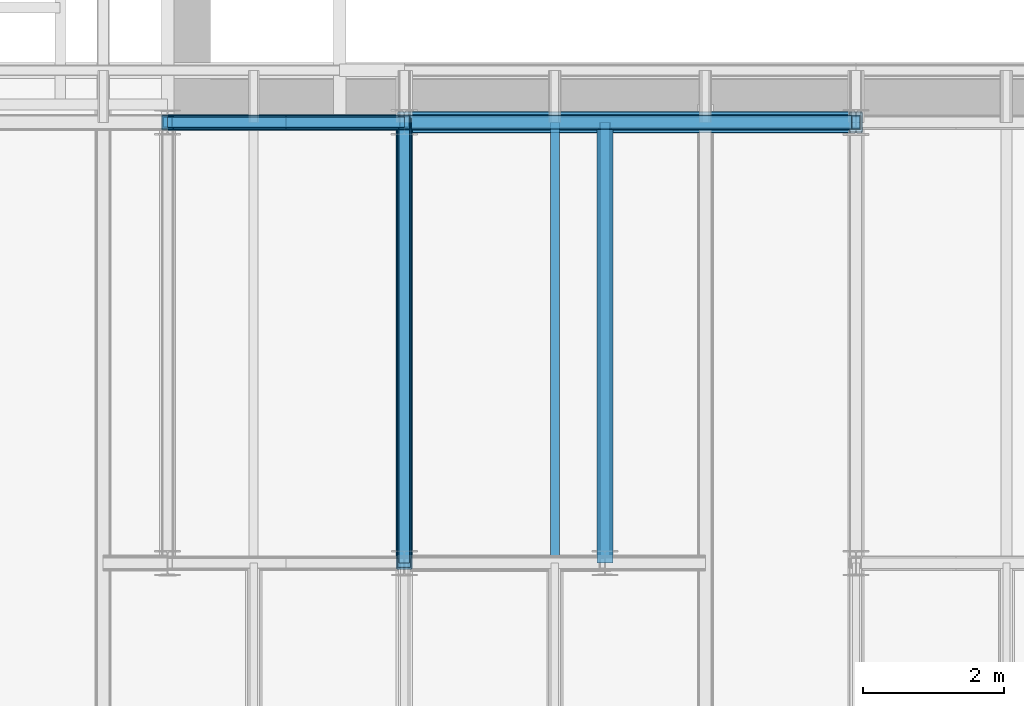
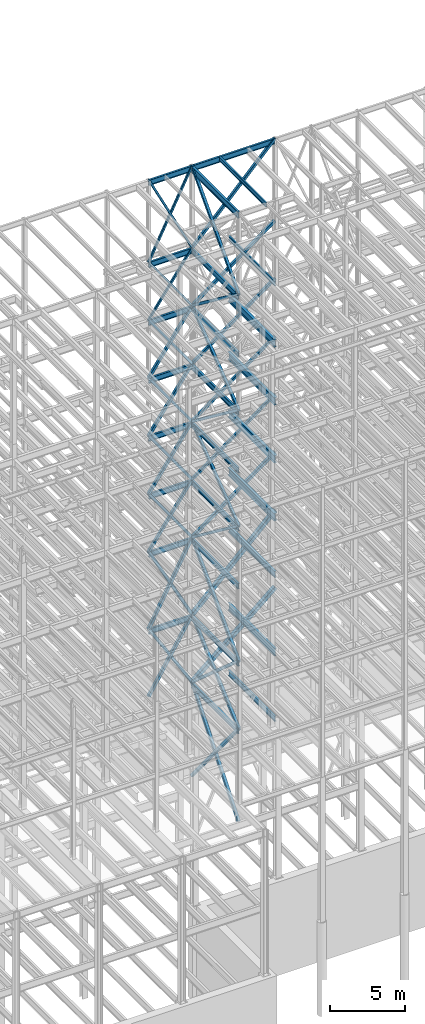
# One storey, part 135 of 150: 62 beams.
"""IFC2X3 building model written with IfcOpenShell, lengths in millimetres."""

from ifc_helpers import new_model, si_unit, frame, origin_with_axes, origin_2d_with_axis, place, context, subcontext, project, spatial, hollow_rectangle, i_section, extrude, material, type_object, element, save


model = new_model("IFC2X3")

# Units and contexts
model_context = context("Model", 3, precision=1e-05, world=origin_with_axes())
body_context = subcontext(model_context, "Body", "Model", "MODEL_VIEW")
ifc_project = project(units=[si_unit("LENGTHUNIT", "METRE", prefix="MILLI"), si_unit("AREAUNIT", "SQUARE_METRE"), si_unit("VOLUMEUNIT", "CUBIC_METRE"), si_unit("MASSUNIT", "GRAM", prefix="KILO"), si_unit("TIMEUNIT", "SECOND"), si_unit("PLANEANGLEUNIT", "RADIAN"), si_unit("SOLIDANGLEUNIT", "STERADIAN"), si_unit("THERMODYNAMICTEMPERATUREUNIT", "DEGREE_CELSIUS"), si_unit("LUMINOUSINTENSITYUNIT", "LUMEN")], contexts=[model_context])

# Site, building, storey
site_placement = place(None, origin_with_axes())
site = spatial("IfcSite", under=ifc_project, at=site_placement, CompositionType="ELEMENT")
building_placement = place(site_placement, origin_with_axes())
building = spatial("IfcBuilding", under=site, at=building_placement, Name="Undefined", CompositionType="ELEMENT")
storey_placement = place(building_placement, origin_with_axes())
storey = spatial("IfcBuildingStorey", under=building, at=storey_placement, Name="Undefined", CompositionType="ELEMENT", Elevation=0.0)

# Beams
ifc_material_1 = material()
beam_type_1 = type_object("IfcBeamType", Name="HSS8X8X3/8", PredefinedType="NOTDEFINED")
for number, where, z_axis, x_axis, name in (
    (1, (56591.2, 31877.0, 45034.2), (0.0, 0.603108242282795, 0.797659355922412), (0.0, -0.797659355922412, 0.603108242282795), "BEAM"),
    (2, (56591.2, 25628.6, 40309.8), (0.0, -0.603108242282795, 0.797659355922412), (0.0, 0.797659355922412, 0.603108242282795), "BEAM"),
    (3, (56591.2, 31877.0, 35585.4), (0.0, 0.603108242282795, 0.797659355922412), (0.0, -0.797659355922412, 0.603108242282795), "BEAM"),
):
    element("IfcBeam", number, at=place(storey_placement, frame(where, z_axis=z_axis, x_axis=x_axis)), inside=storey, type_object=beam_type_1, material=ifc_material_1, Name=name, ObjectType="HSS8X8X3/8", context=body_context, shape_type="SweptSolid", body=[
        extrude(hollow_rectangle(XDim=203.2, YDim=203.2, WallThickness=9.525, InnerFilletRadius=9.5249, OuterFilletRadius=19.0499, at=origin_2d_with_axis()), frame((7833.41929938644, 0.0, 0.0), z_axis=(-1.0, 0.0, 0.0), x_axis=(0.0, -1.0, 0.0)), (0.0, 0.0, 1.0), 7833.41929938644),
    ])
beam_1_placement = place(storey_placement, frame((56591.2, 31877.0, 49758.6), z_axis=(-0.593852272176556, 0.0, 0.804574097787607), x_axis=(0.804574097787604, 0.0, 0.59385227217656)))
element("IfcBeam", 4, at=beam_1_placement, inside=storey, type_object=beam_type_1, material=ifc_material_1, Name="BEAM", ObjectType="HSS8X8X3/8", context=body_context, shape_type="SweptSolid", body=[
    extrude(hollow_rectangle(XDim=203.2, YDim=203.2, WallThickness=9.525, InnerFilletRadius=9.5249, OuterFilletRadius=19.0499, at=origin_2d_with_axis()), frame((7955.51355978985, 0.0, -1.81898940354586e-12), z_axis=(-1.0, 0.0, 0.0), x_axis=(0.0, -1.0, 0.0)), (0.0, 0.0, 1.0), 7955.51355978984),
])
for number, where, z_axis, x_axis, name in (
    (5, (56591.2, 31877.0, 40309.8), (0.815507132555285, 0.0, 0.578747023103753), (-0.578747023103752, 0.0, 0.815507132555286), "BEAM"),
    (6, (53238.4, 31877.0, 40309.8), (-0.815507179752522, 0.0, 0.578746956598553), (0.578746956598556, 0.0, 0.81550717975252), "BEAM"),
    (7, (56591.2, 31877.0, 35585.4), (0.815507132555285, 0.0, 0.578747023103753), (-0.578747023103752, 0.0, 0.815507132555286), "BEAM"),
    (8, (53238.4, 31877.0, 35585.4), (-0.815507179752522, 0.0, 0.578746956598553), (0.578746956598556, 0.0, 0.81550717975252), "BEAM"),
):
    element("IfcBeam", number, at=place(storey_placement, frame(where, z_axis=z_axis, x_axis=x_axis)), inside=storey, type_object=beam_type_1, material=ifc_material_1, Name=name, ObjectType="HSS8X8X3/8", context=body_context, shape_type="SweptSolid", body=[
        extrude(hollow_rectangle(XDim=203.2, YDim=203.2, WallThickness=9.525, InnerFilletRadius=9.5249, OuterFilletRadius=19.0499, at=origin_2d_with_axis()), frame((5793.20491610646, 0.0, -3.21587474211652e-13), z_axis=(-1.0, 0.0, 0.0), x_axis=(0.0, -1.0, 0.0)), (0.0, 0.0, 1.0), 5793.20491610646),
    ])
ifc_material_2 = material(Name="STEEL/A992")
beam_type_2 = type_object("IfcBeamType", Name="W18X35", PredefinedType="NOTDEFINED")
beam_2_placement = place(storey_placement, frame((56591.2, 31877.0, 65687.575), z_axis=(0.0, 0.0, 1.0), x_axis=(1.0, 0.0, 0.0)))
element("IfcBeam", 9, at=beam_2_placement, inside=storey, type_object=beam_type_2, material=ifc_material_2, Name="BEAM", ObjectType="W18X35", context=body_context, shape_type="SweptSolid", body=[
    extrude(i_section(OverallWidth=152.4, OverallDepth=450.85, WebThickness=7.9375, FlangeThickness=10.795, FilletRadius=17.78, at=origin_2d_with_axis()), frame((6400.80000000001, 0.0, 0.0), z_axis=(-1.0, 0.0, 0.0), x_axis=(0.0, -1.0, 0.0)), (0.0, 0.0, 1.0), 6400.80000000001),
])
beam_3_placement = place(storey_placement, frame((53238.4, 31877.0, 65687.575), z_axis=(0.0, 0.0, 1.0), x_axis=(1.0, 0.0, 0.0)))
element("IfcBeam", 10, at=beam_3_placement, inside=storey, type_object=beam_type_2, material=ifc_material_2, Name="BEAM", ObjectType="W18X35", context=body_context, shape_type="SweptSolid", body=[
    extrude(i_section(OverallWidth=152.4, OverallDepth=450.85, WebThickness=7.9375, FlangeThickness=10.795, FilletRadius=17.78, at=origin_2d_with_axis()), frame((3352.8, 0.0, 0.0), z_axis=(-1.0, 0.0, 0.0), x_axis=(0.0, -1.0, 0.0)), (0.0, 0.0, 1.0), 3352.8),
])
beam_4_placement = place(storey_placement, frame((56591.2, 25628.6, 58981.975), z_axis=(0.0, 0.0, 1.0), x_axis=(0.0, 1.0, 0.0)))
element("IfcBeam", 11, at=beam_4_placement, inside=storey, type_object=beam_type_2, material=ifc_material_2, Name="BEAM", ObjectType="W18X35", context=body_context, shape_type="SweptSolid", body=[
    extrude(i_section(OverallWidth=152.4, OverallDepth=450.85, WebThickness=7.9375, FlangeThickness=10.795, FilletRadius=17.78, at=origin_2d_with_axis()), frame((6248.40000000001, 0.0, 0.0), z_axis=(-1.0, 0.0, 0.0), x_axis=(0.0, -1.0, 0.0)), (0.0, 0.0, 1.0), 6248.40000000001),
])
beam_5_placement = place(storey_placement, frame((53238.4, 31877.0, 58981.975), z_axis=(0.0, 0.0, 1.0), x_axis=(1.0, 0.0, 0.0)))
element("IfcBeam", 12, at=beam_5_placement, inside=storey, type_object=beam_type_2, material=ifc_material_2, Name="BEAM", ObjectType="W18X35", context=body_context, shape_type="SweptSolid", body=[
    extrude(i_section(OverallWidth=152.4, OverallDepth=450.85, WebThickness=7.9375, FlangeThickness=10.795, FilletRadius=17.78, at=origin_2d_with_axis()), frame((3352.8, 0.0, 0.0), z_axis=(-1.0, 0.0, 0.0), x_axis=(0.0, -1.0, 0.0)), (0.0, 0.0, 1.0), 3352.8),
])
beam_6_placement = place(storey_placement, frame((56591.2, 25628.6, 54257.575), z_axis=(0.0, 0.0, 1.0), x_axis=(0.0, 1.0, 0.0)))
element("IfcBeam", 13, at=beam_6_placement, inside=storey, type_object=beam_type_2, material=ifc_material_2, Name="BEAM", ObjectType="W18X35", context=body_context, shape_type="SweptSolid", body=[
    extrude(i_section(OverallWidth=152.4, OverallDepth=450.85, WebThickness=7.9375, FlangeThickness=10.795, FilletRadius=17.78, at=origin_2d_with_axis()), frame((6248.40000000001, 0.0, 0.0), z_axis=(-1.0, 0.0, 0.0), x_axis=(0.0, -1.0, 0.0)), (0.0, 0.0, 1.0), 6248.40000000001),
])
beam_7_placement = place(storey_placement, frame((53238.4, 31877.0, 54257.575), z_axis=(0.0, 0.0, 1.0), x_axis=(1.0, 0.0, 0.0)))
element("IfcBeam", 14, at=beam_7_placement, inside=storey, type_object=beam_type_2, material=ifc_material_2, Name="BEAM", ObjectType="W18X35", context=body_context, shape_type="SweptSolid", body=[
    extrude(i_section(OverallWidth=152.4, OverallDepth=450.85, WebThickness=7.9375, FlangeThickness=10.795, FilletRadius=17.78, at=origin_2d_with_axis()), frame((3352.8, 0.0, 0.0), z_axis=(-1.0, 0.0, 0.0), x_axis=(0.0, -1.0, 0.0)), (0.0, 0.0, 1.0), 3352.8),
])
beam_8_placement = place(storey_placement, frame((56591.2, 25628.6, 49533.175), z_axis=(0.0, 0.0, 1.0), x_axis=(0.0, 1.0, 0.0)))
element("IfcBeam", 15, at=beam_8_placement, inside=storey, type_object=beam_type_2, material=ifc_material_2, Name="BEAM", ObjectType="W18X35", context=body_context, shape_type="SweptSolid", body=[
    extrude(i_section(OverallWidth=152.4, OverallDepth=450.85, WebThickness=7.9375, FlangeThickness=10.795, FilletRadius=17.78, at=origin_2d_with_axis()), frame((6248.40000000001, 0.0, 0.0), z_axis=(-1.0, 0.0, 0.0), x_axis=(0.0, -1.0, 0.0)), (0.0, 0.0, 1.0), 6248.40000000001),
])
beam_9_placement = place(storey_placement, frame((53238.4, 31877.0, 49533.175), z_axis=(0.0, 0.0, 1.0), x_axis=(1.0, 0.0, 0.0)))
element("IfcBeam", 16, at=beam_9_placement, inside=storey, type_object=beam_type_2, material=ifc_material_2, Name="BEAM", ObjectType="W18X35", context=body_context, shape_type="SweptSolid", body=[
    extrude(i_section(OverallWidth=152.4, OverallDepth=450.85, WebThickness=7.9375, FlangeThickness=10.795, FilletRadius=17.78, at=origin_2d_with_axis()), frame((3352.8, 0.0, 0.0), z_axis=(-1.0, 0.0, 0.0), x_axis=(0.0, -1.0, 0.0)), (0.0, 0.0, 1.0), 3352.8),
])
beam_10_placement = place(storey_placement, frame((56591.2, 25628.6, 44808.775), z_axis=(0.0, 0.0, 1.0), x_axis=(0.0, 1.0, 0.0)))
element("IfcBeam", 17, at=beam_10_placement, inside=storey, type_object=beam_type_2, material=ifc_material_2, Name="BEAM", ObjectType="W18X35", context=body_context, shape_type="SweptSolid", body=[
    extrude(i_section(OverallWidth=152.4, OverallDepth=450.85, WebThickness=7.9375, FlangeThickness=10.795, FilletRadius=17.78, at=origin_2d_with_axis()), frame((6248.40000000001, 0.0, 0.0), z_axis=(-1.0, 0.0, 0.0), x_axis=(0.0, -1.0, 0.0)), (0.0, 0.0, 1.0), 6248.40000000001),
])
beam_11_placement = place(storey_placement, frame((53238.4, 31877.0, 44808.775), z_axis=(0.0, 0.0, 1.0), x_axis=(1.0, 0.0, 0.0)))
element("IfcBeam", 18, at=beam_11_placement, inside=storey, type_object=beam_type_2, material=ifc_material_2, Name="BEAM", ObjectType="W18X35", context=body_context, shape_type="SweptSolid", body=[
    extrude(i_section(OverallWidth=152.4, OverallDepth=450.85, WebThickness=7.9375, FlangeThickness=10.795, FilletRadius=17.78, at=origin_2d_with_axis()), frame((3352.8, 0.0, 0.0), z_axis=(-1.0, 0.0, 0.0), x_axis=(0.0, -1.0, 0.0)), (0.0, 0.0, 1.0), 3352.8),
])
beam_12_placement = place(storey_placement, frame((56591.2, 25628.6, 40084.375), z_axis=(0.0, 0.0, 1.0), x_axis=(0.0, 1.0, 0.0)))
element("IfcBeam", 19, at=beam_12_placement, inside=storey, type_object=beam_type_2, material=ifc_material_2, Name="BEAM", ObjectType="W18X35", context=body_context, shape_type="SweptSolid", body=[
    extrude(i_section(OverallWidth=152.4, OverallDepth=450.85, WebThickness=7.9375, FlangeThickness=10.795, FilletRadius=17.78, at=origin_2d_with_axis()), frame((6248.40000000001, 0.0, 0.0), z_axis=(-1.0, 0.0, 0.0), x_axis=(0.0, -1.0, 0.0)), (0.0, 0.0, 1.0), 6248.40000000001),
])
beam_13_placement = place(storey_placement, frame((53238.4, 31877.0, 40084.375), z_axis=(0.0, 0.0, 1.0), x_axis=(1.0, 0.0, 0.0)))
element("IfcBeam", 20, at=beam_13_placement, inside=storey, type_object=beam_type_2, material=ifc_material_2, Name="BEAM", ObjectType="W18X35", context=body_context, shape_type="SweptSolid", body=[
    extrude(i_section(OverallWidth=152.4, OverallDepth=450.85, WebThickness=7.9375, FlangeThickness=10.795, FilletRadius=17.78, at=origin_2d_with_axis()), frame((3352.8, 0.0, 0.0), z_axis=(-1.0, 0.0, 0.0), x_axis=(0.0, -1.0, 0.0)), (0.0, 0.0, 1.0), 3352.8),
])
beam_14_placement = place(storey_placement, frame((56591.2, 25628.6, 35359.975), z_axis=(0.0, 0.0, 1.0), x_axis=(0.0, 1.0, 0.0)))
element("IfcBeam", 21, at=beam_14_placement, inside=storey, type_object=beam_type_2, material=ifc_material_2, Name="BEAM", ObjectType="W18X35", context=body_context, shape_type="SweptSolid", body=[
    extrude(i_section(OverallWidth=152.4, OverallDepth=450.85, WebThickness=7.9375, FlangeThickness=10.795, FilletRadius=17.78, at=origin_2d_with_axis()), frame((6248.40000000001, 0.0, 0.0), z_axis=(-1.0, 0.0, 0.0), x_axis=(0.0, -1.0, 0.0)), (0.0, 0.0, 1.0), 6248.40000000001),
])
beam_15_placement = place(storey_placement, frame((53238.4, 31877.0, 35359.975), z_axis=(0.0, 0.0, 1.0), x_axis=(1.0, 0.0, 0.0)))
element("IfcBeam", 22, at=beam_15_placement, inside=storey, type_object=beam_type_2, material=ifc_material_2, Name="BEAM", ObjectType="W18X35", context=body_context, shape_type="SweptSolid", body=[
    extrude(i_section(OverallWidth=152.4, OverallDepth=450.85, WebThickness=7.9375, FlangeThickness=10.795, FilletRadius=17.78, at=origin_2d_with_axis()), frame((3352.8, 0.0, 0.0), z_axis=(-1.0, 0.0, 0.0), x_axis=(0.0, -1.0, 0.0)), (0.0, 0.0, 1.0), 3352.8),
])
beam_16_placement = place(storey_placement, frame((56591.2, 25628.6, 29060.775), z_axis=(0.0, 0.0, 1.0), x_axis=(0.0, 1.0, 0.0)))
element("IfcBeam", 23, at=beam_16_placement, inside=storey, type_object=beam_type_2, material=ifc_material_2, Name="BEAM", ObjectType="W18X35", context=body_context, shape_type="SweptSolid", body=[
    extrude(i_section(OverallWidth=152.4, OverallDepth=450.85, WebThickness=7.9375, FlangeThickness=10.795, FilletRadius=17.78, at=origin_2d_with_axis()), frame((6248.40000000001, 0.0, 0.0), z_axis=(-1.0, 0.0, 0.0), x_axis=(0.0, -1.0, 0.0)), (0.0, 0.0, 1.0), 6248.40000000001),
])
beam_17_placement = place(storey_placement, frame((53238.4, 31877.0, 29060.775), z_axis=(0.0, 0.0, 1.0), x_axis=(1.0, 0.0, 0.0)))
element("IfcBeam", 24, at=beam_17_placement, inside=storey, type_object=beam_type_2, material=ifc_material_2, Name="BEAM", ObjectType="W18X35", context=body_context, shape_type="SweptSolid", body=[
    extrude(i_section(OverallWidth=152.4, OverallDepth=450.85, WebThickness=7.9375, FlangeThickness=10.795, FilletRadius=17.78, at=origin_2d_with_axis()), frame((3352.8, 0.0, 0.0), z_axis=(-1.0, 0.0, 0.0), x_axis=(0.0, -1.0, 0.0)), (0.0, 0.0, 1.0), 3352.8),
])
for number, where, z_axis, x_axis, name in (
    (25, (59436.0, 25628.6, 23548.975), (0.0, 0.0, 1.0), (0.0, 1.0, 0.0), "BEAM"),
    (26, (56591.2, 25628.6, 23548.975), (0.0, 0.0, 1.0), (0.0, 1.0, 0.0), "BEAM"),
):
    element("IfcBeam", number, at=place(storey_placement, frame(where, z_axis=z_axis, x_axis=x_axis)), inside=storey, type_object=beam_type_2, material=ifc_material_2, Name=name, ObjectType="W18X35", context=body_context, shape_type="SweptSolid", body=[
        extrude(i_section(OverallWidth=152.4, OverallDepth=450.85, WebThickness=7.9375, FlangeThickness=10.795, FilletRadius=17.78, at=origin_2d_with_axis()), frame((6248.40000000001, 0.0, 0.0), z_axis=(-1.0, 0.0, 0.0), x_axis=(0.0, -1.0, 0.0)), (0.0, 0.0, 1.0), 6248.40000000001),
    ])
beam_type_3 = type_object("IfcBeamType", Name="HSS12X12X1/2", PredefinedType="NOTDEFINED")
beam_18_placement = place(storey_placement, frame((56591.2, 31877.0, 29286.2), z_axis=(-0.701427454200915, 0.0, 0.712740855075127), x_axis=(0.712740855075127, 0.0, 0.701427454200915)))
element("IfcBeam", 27, at=beam_18_placement, inside=storey, type_object=beam_type_3, material=ifc_material_1, Name="BEAM", ObjectType="HSS12X12X1/2", context=body_context, shape_type="SweptSolid", body=[
    extrude(hollow_rectangle(XDim=304.8, YDim=304.8, WallThickness=12.7, InnerFilletRadius=12.6999, OuterFilletRadius=25.3999, at=origin_2d_with_axis()), frame((8980.54348466728, 3.63797880709171e-12, -8.27299822921593e-12), z_axis=(-1.0, 0.0, 0.0), x_axis=(0.0, -1.0, 0.0)), (0.0, 0.0, 1.0), 8980.54348466729),
])
beam_19_placement = place(storey_placement, frame((56591.2, 31877.0, 23774.4), z_axis=(-0.652523116219427, 0.0, 0.75776881883546), x_axis=(0.757768818835462, 0.0, 0.652523116219425)))
element("IfcBeam", 28, at=beam_19_placement, inside=storey, type_object=beam_type_3, material=ifc_material_1, Name="BEAM", ObjectType="HSS12X12X1/2", context=body_context, shape_type="SweptSolid", body=[
    extrude(hollow_rectangle(XDim=304.8, YDim=304.8, WallThickness=12.7, InnerFilletRadius=12.6999, OuterFilletRadius=25.3999, at=origin_2d_with_axis()), frame((8446.90356758025, 0.0, 0.0), z_axis=(-1.0, 0.0, 0.0), x_axis=(0.0, -1.0, 0.0)), (0.0, 0.0, 1.0), 8446.90356758025),
])
beam_type_4 = type_object("IfcBeamType", Name="HSS8X8X1/4", PredefinedType="NOTDEFINED")
beam_20_placement = place(storey_placement, frame((56591.2, 25628.6, 59207.4), z_axis=(0.0, -0.73160798168672, 0.681725576117168), x_axis=(0.0, 0.681725576117167, 0.731607981686721)))
element("IfcBeam", 29, at=beam_20_placement, inside=storey, type_object=beam_type_4, material=ifc_material_1, Name="BEAM", ObjectType="HSS8X8X1/4", context=body_context, shape_type="SweptSolid", body=[
    extrude(hollow_rectangle(XDim=203.2, YDim=203.2, WallThickness=6.35, InnerFilletRadius=6.3499, OuterFilletRadius=12.6999, at=origin_2d_with_axis()), frame((9165.56427236196, 0.0, -1.0175820488858e-12), z_axis=(-1.0, 0.0, 0.0), x_axis=(0.0, -1.0, 0.0)), (0.0, 0.0, 1.0), 9165.56427241015),
])
for number, where, z_axis, x_axis, name in (
    (30, (56591.2, 31877.0, 54483.0), (0.0, 0.603108242282795, 0.797659355922412), (0.0, -0.797659355922412, 0.603108242282795), "BEAM"),
    (31, (56591.2, 25628.6, 49758.6), (0.0, -0.603108242282795, 0.797659355922412), (0.0, 0.797659355922412, 0.603108242282795), "BEAM"),
):
    element("IfcBeam", number, at=place(storey_placement, frame(where, z_axis=z_axis, x_axis=x_axis)), inside=storey, type_object=beam_type_4, material=ifc_material_1, Name=name, ObjectType="HSS8X8X1/4", context=body_context, shape_type="SweptSolid", body=[
        extrude(hollow_rectangle(XDim=203.2, YDim=203.2, WallThickness=6.35, InnerFilletRadius=6.3499, OuterFilletRadius=12.6999, at=origin_2d_with_axis()), frame((7833.41929938644, 0.0, 0.0), z_axis=(-1.0, 0.0, 0.0), x_axis=(0.0, -1.0, 0.0)), (0.0, 0.0, 1.0), 7833.41929938644),
    ])
beam_21_placement = place(storey_placement, frame((56591.2, 31877.0, 59207.4), z_axis=(-0.723355546413844, 0.0, 0.690475744304121), x_axis=(0.690475744304122, 0.0, 0.723355546413843)))
element("IfcBeam", 32, at=beam_21_placement, inside=storey, type_object=beam_type_4, material=ifc_material_1, Name="BEAM", ObjectType="HSS8X8X1/4", context=body_context, shape_type="SweptSolid", body=[
    extrude(hollow_rectangle(XDim=203.2, YDim=203.2, WallThickness=6.35, InnerFilletRadius=6.3499, OuterFilletRadius=12.6999, at=origin_2d_with_axis()), frame((9270.13009617449, 3.63797880709171e-12, 0.0), z_axis=(-1.0, 0.0, 0.0), x_axis=(0.0, -1.0, 0.0)), (0.0, 0.0, 1.0), 9270.13009617449),
])
beam_22_placement = place(storey_placement, frame((56591.2, 31877.0, 54483.0), z_axis=(-0.593852272176556, 0.0, 0.804574097787607), x_axis=(0.804574097787604, 0.0, 0.59385227217656)))
element("IfcBeam", 33, at=beam_22_placement, inside=storey, type_object=beam_type_4, material=ifc_material_1, Name="BEAM", ObjectType="HSS8X8X1/4", context=body_context, shape_type="SweptSolid", body=[
    extrude(hollow_rectangle(XDim=203.2, YDim=203.2, WallThickness=6.35, InnerFilletRadius=6.3499, OuterFilletRadius=12.6999, at=origin_2d_with_axis()), frame((7955.51355978985, 0.0, -1.81898940354586e-12), z_axis=(-1.0, 0.0, 0.0), x_axis=(0.0, -1.0, 0.0)), (0.0, 0.0, 1.0), 7955.51355978984),
])
beam_23_placement = place(storey_placement, frame((56591.2, 31877.0, 49758.6), z_axis=(0.815507132555285, 0.0, 0.578747023103753), x_axis=(-0.578747023103752, 0.0, 0.815507132555286)))
element("IfcBeam", 34, at=beam_23_placement, inside=storey, type_object=beam_type_4, material=ifc_material_1, Name="BEAM", ObjectType="HSS8X8X1/4", context=body_context, shape_type="SweptSolid", body=[
    extrude(hollow_rectangle(XDim=203.2, YDim=203.2, WallThickness=6.35, InnerFilletRadius=6.3499, OuterFilletRadius=12.6999, at=origin_2d_with_axis()), frame((5793.20491610646, 0.0, -3.21587474211652e-13), z_axis=(-1.0, 0.0, 0.0), x_axis=(0.0, -1.0, 0.0)), (0.0, 0.0, 1.0), 5793.20491610647),
])
beam_24_placement = place(storey_placement, frame((53238.4, 31877.0, 49758.6), z_axis=(-0.815507179752522, 0.0, 0.578746956598553), x_axis=(0.578746956598556, 0.0, 0.81550717975252)))
element("IfcBeam", 35, at=beam_24_placement, inside=storey, type_object=beam_type_4, material=ifc_material_1, Name="BEAM", ObjectType="HSS8X8X1/4", context=body_context, shape_type="SweptSolid", body=[
    extrude(hollow_rectangle(XDim=203.2, YDim=203.2, WallThickness=6.35, InnerFilletRadius=6.3499, OuterFilletRadius=12.6999, at=origin_2d_with_axis()), frame((5793.20491610646, 0.0, -3.21587474211652e-13), z_axis=(-1.0, 0.0, 0.0), x_axis=(0.0, -1.0, 0.0)), (0.0, 0.0, 1.0), 5793.20491610646),
])
beam_25_placement = place(storey_placement, frame((56591.2, 31877.0, 45034.2), z_axis=(0.815507132555285, 0.0, 0.578747023103753), x_axis=(-0.578747023103752, 0.0, 0.815507132555286)))
element("IfcBeam", 36, at=beam_25_placement, inside=storey, type_object=beam_type_4, material=ifc_material_1, Name="BEAM", ObjectType="HSS8X8X1/4", context=body_context, shape_type="SweptSolid", body=[
    extrude(hollow_rectangle(XDim=203.2, YDim=203.2, WallThickness=6.35, InnerFilletRadius=6.3499, OuterFilletRadius=12.6999, at=origin_2d_with_axis()), frame((5793.20491610646, 0.0, -3.21587474211652e-13), z_axis=(-1.0, 0.0, 0.0), x_axis=(0.0, -1.0, 0.0)), (0.0, 0.0, 1.0), 5793.20491610647),
])
beam_26_placement = place(storey_placement, frame((53238.4, 31877.0, 45034.2), z_axis=(-0.815507179752522, 0.0, 0.578746956598553), x_axis=(0.578746956598556, 0.0, 0.81550717975252)))
element("IfcBeam", 37, at=beam_26_placement, inside=storey, type_object=beam_type_4, material=ifc_material_1, Name="BEAM", ObjectType="HSS8X8X1/4", context=body_context, shape_type="SweptSolid", body=[
    extrude(hollow_rectangle(XDim=203.2, YDim=203.2, WallThickness=6.35, InnerFilletRadius=6.3499, OuterFilletRadius=12.6999, at=origin_2d_with_axis()), frame((5793.20491610646, 0.0, -3.21587474211652e-13), z_axis=(-1.0, 0.0, 0.0), x_axis=(0.0, -1.0, 0.0)), (0.0, 0.0, 1.0), 5793.20491610646),
])
beam_type_5 = type_object("IfcBeamType", Name="HSS8X8X1/2", PredefinedType="NOTDEFINED")
beam_27_placement = place(storey_placement, frame((56591.2, 31877.0, 45034.2), z_axis=(-0.593852272176556, 0.0, 0.804574097787607), x_axis=(0.804574097787604, 0.0, 0.59385227217656)))
element("IfcBeam", 38, at=beam_27_placement, inside=storey, type_object=beam_type_5, material=ifc_material_1, Name="BEAM", ObjectType="HSS8X8X1/2", context=body_context, shape_type="SweptSolid", body=[
    extrude(hollow_rectangle(XDim=203.2, YDim=203.2, WallThickness=12.7, InnerFilletRadius=12.6999, OuterFilletRadius=25.3999, at=origin_2d_with_axis()), frame((7955.51355978985, 0.0, -1.81898940354586e-12), z_axis=(-1.0, 0.0, 0.0), x_axis=(0.0, -1.0, 0.0)), (0.0, 0.0, 1.0), 7955.51355978985),
])
beam_type_6 = type_object("IfcBeamType", Name="HSS6X6X1/4", PredefinedType="NOTDEFINED")
for number, where, z_axis, x_axis, name in (
    (39, (56591.2, 31877.0, 59207.4), (0.894427210999918, 0.0, 0.447213555499951), (-0.447213555499953, 0.0, 0.894427210999917), "BEAM"),
    (40, (53238.4, 31877.0, 59207.4), (-0.894427210999918, 0.0, 0.447213555499951), (0.447213555499953, 0.0, 0.894427210999917), "BEAM"),
):
    element("IfcBeam", number, at=place(storey_placement, frame(where, z_axis=z_axis, x_axis=x_axis)), inside=storey, type_object=beam_type_6, material=ifc_material_1, Name=name, ObjectType="HSS6X6X1/4", context=body_context, shape_type="SweptSolid", body=[
        extrude(hollow_rectangle(XDim=152.4, YDim=152.4, WallThickness=6.35, InnerFilletRadius=6.3499, OuterFilletRadius=12.6999, at=origin_2d_with_axis()), frame((7497.08871496129, 0.0, 0.0), z_axis=(-1.0, 0.0, 0.0), x_axis=(0.0, -1.0, 0.0)), (0.0, 0.0, 1.0), 7497.08871496129),
    ])
for number, where, z_axis, x_axis, name in (
    (41, (56591.2, 31877.0, 54483.0), (0.815507132555285, 0.0, 0.578747023103753), (-0.578747023103752, 0.0, 0.815507132555286), "BEAM"),
    (42, (53238.4, 31877.0, 54483.0), (-0.815507179752522, 0.0, 0.578746956598553), (0.578746956598556, 0.0, 0.81550717975252), "BEAM"),
):
    element("IfcBeam", number, at=place(storey_placement, frame(where, z_axis=z_axis, x_axis=x_axis)), inside=storey, type_object=beam_type_6, material=ifc_material_1, Name=name, ObjectType="HSS6X6X1/4", context=body_context, shape_type="SweptSolid", body=[
        extrude(hollow_rectangle(XDim=152.4, YDim=152.4, WallThickness=6.35, InnerFilletRadius=6.3499, OuterFilletRadius=12.6999, at=origin_2d_with_axis()), frame((5793.20491610646, 0.0, -3.21587474211652e-13), z_axis=(-1.0, 0.0, 0.0), x_axis=(0.0, -1.0, 0.0)), (0.0, 0.0, 1.0), 5793.20491610646),
    ])
beam_type_7 = type_object("IfcBeamType", Name="HSS9X9X1/2", PredefinedType="NOTDEFINED")
beam_28_placement = place(storey_placement, frame((56591.2, 25628.6, 23774.4), z_axis=(0.0, -0.661520808536634, 0.749926809677477), x_axis=(0.0, 0.749926809677476, 0.661520808536635)))
element("IfcBeam", 43, at=beam_28_placement, inside=storey, type_object=beam_type_7, material=ifc_material_1, Name="BEAM", ObjectType="HSS9X9X1/2", context=body_context, shape_type="SweptSolid", body=[
    extrude(hollow_rectangle(XDim=228.6, YDim=228.6, WallThickness=12.7, InnerFilletRadius=12.6999, OuterFilletRadius=25.3999, at=origin_2d_with_axis()), frame((8332.01307008096, 0.0, -9.25039275188162e-13), z_axis=(-1.0, 0.0, 0.0), x_axis=(0.0, -1.0, 0.0)), (0.0, 0.0, 1.0), 8332.01307008096),
])
beam_29_placement = place(storey_placement, frame((56591.2, 31877.0, 16154.4), z_axis=(0.0, 0.773267797360785, 0.634079579835843), x_axis=(0.0, -0.634079579835843, 0.773267797360786)))
element("IfcBeam", 44, at=beam_29_placement, inside=storey, type_object=beam_type_7, material=ifc_material_1, Name="BEAM", ObjectType="HSS9X9X1/2", context=body_context, shape_type="SweptSolid", body=[
    extrude(hollow_rectangle(XDim=228.6, YDim=228.6, WallThickness=12.7, InnerFilletRadius=12.6999, OuterFilletRadius=25.3999, at=origin_2d_with_axis()), frame((9854.28346253547, 0.0, 5.47022619564489e-13), z_axis=(-1.0, 0.0, 0.0), x_axis=(0.0, -1.0, 0.0)), (0.0, 0.0, 1.0), 9854.28346253547),
])
beam_30_placement = place(storey_placement, frame((56591.2, 25628.6, 29286.2), z_axis=(0.0, -0.709963736329935, 0.704238236036952), x_axis=(0.0, 0.704238236036953, 0.709963736329935)))
element("IfcBeam", 45, at=beam_30_placement, inside=storey, type_object=beam_type_7, material=ifc_material_1, Name="BEAM", ObjectType="HSS9X9X1/2", context=body_context, shape_type="SweptSolid", body=[
    extrude(hollow_rectangle(XDim=228.6, YDim=228.6, WallThickness=12.7, InnerFilletRadius=12.6999, OuterFilletRadius=25.3999, at=origin_2d_with_axis()), frame((8872.56576194282, 0.0, 0.0), z_axis=(-1.0, 0.0, 0.0), x_axis=(0.0, -1.0, 0.0)), (0.0, 0.0, 1.0), 8872.56576194282),
])
beam_31_placement = place(storey_placement, frame((56591.2, 31877.0, 23774.4), z_axis=(0.0, 0.661520808536634, 0.749926809677477), x_axis=(0.0, -0.749926809677476, 0.661520808536635)))
element("IfcBeam", 46, at=beam_31_placement, inside=storey, type_object=beam_type_7, material=ifc_material_1, Name="BEAM", ObjectType="HSS9X9X1/2", context=body_context, shape_type="SweptSolid", body=[
    extrude(hollow_rectangle(XDim=228.6, YDim=228.6, WallThickness=12.7, InnerFilletRadius=12.6999, OuterFilletRadius=25.3999, at=origin_2d_with_axis()), frame((8332.01307008096, 0.0, -9.25039275188162e-13), z_axis=(-1.0, 0.0, 0.0), x_axis=(0.0, -1.0, 0.0)), (0.0, 0.0, 1.0), 8332.01307008096),
])
beam_32_placement = place(storey_placement, frame((56591.2, 25628.6, 16154.4), z_axis=(0.0, -0.773267797360785, 0.634079579835843), x_axis=(0.0, 0.634079579835843, 0.773267797360786)))
element("IfcBeam", 47, at=beam_32_placement, inside=storey, type_object=beam_type_7, material=ifc_material_1, Name="BEAM", ObjectType="HSS9X9X1/2", context=body_context, shape_type="SweptSolid", body=[
    extrude(hollow_rectangle(XDim=228.6, YDim=228.6, WallThickness=12.7, InnerFilletRadius=12.6999, OuterFilletRadius=25.3999, at=origin_2d_with_axis()), frame((9854.28346253547, 0.0, 5.47022619564489e-13), z_axis=(-1.0, 0.0, 0.0), x_axis=(0.0, -1.0, 0.0)), (0.0, 0.0, 1.0), 9854.28346253547),
])
beam_33_placement = place(storey_placement, frame((56591.2, 31877.0, 35585.4), z_axis=(-0.593852272176556, 0.0, 0.804574097787607), x_axis=(0.804574097787604, 0.0, 0.59385227217656)))
element("IfcBeam", 48, at=beam_33_placement, inside=storey, type_object=beam_type_7, material=ifc_material_1, Name="BEAM", ObjectType="HSS9X9X1/2", context=body_context, shape_type="SweptSolid", body=[
    extrude(hollow_rectangle(XDim=228.6, YDim=228.6, WallThickness=12.7, InnerFilletRadius=12.6999, OuterFilletRadius=25.3999, at=origin_2d_with_axis()), frame((7955.51355978985, 0.0, -1.81898940354586e-12), z_axis=(-1.0, 0.0, 0.0), x_axis=(0.0, -1.0, 0.0)), (0.0, 0.0, 1.0), 7955.51355978984),
])
beam_type_8 = type_object("IfcBeamType", Name="HSS8X8X5/8", PredefinedType="NOTDEFINED")
beam_34_placement = place(storey_placement, frame((56591.2, 31877.0, 40309.8), z_axis=(-0.593852272176556, 0.0, 0.804574097787607), x_axis=(0.804574097787604, 0.0, 0.59385227217656)))
element("IfcBeam", 49, at=beam_34_placement, inside=storey, type_object=beam_type_8, material=ifc_material_1, Name="BEAM", ObjectType="HSS8X8X5/8", context=body_context, shape_type="SweptSolid", body=[
    extrude(hollow_rectangle(XDim=203.2, YDim=203.2, WallThickness=15.875, InnerFilletRadius=15.875, OuterFilletRadius=31.75, at=origin_2d_with_axis()), frame((7955.51355978985, 0.0, -1.81898940354586e-12), z_axis=(-1.0, 0.0, 0.0), x_axis=(0.0, -1.0, 0.0)), (0.0, 0.0, 1.0), 7955.51355978984),
])
beam_type_9 = type_object("IfcBeamType", Name="HSS9X9X5/8", PredefinedType="NOTDEFINED")
beam_35_placement = place(storey_placement, frame((56591.2, 31877.0, 29286.2), z_axis=(0.882746779817135, 0.0, 0.469849042483306), x_axis=(-0.469849042483309, 0.0, 0.882746779817133)))
element("IfcBeam", 50, at=beam_35_placement, inside=storey, type_object=beam_type_9, material=ifc_material_1, Name="BEAM", ObjectType="HSS9X9X5/8", context=body_context, shape_type="SweptSolid", body=[
    extrude(hollow_rectangle(XDim=228.6, YDim=228.6, WallThickness=15.875, InnerFilletRadius=15.875, OuterFilletRadius=31.75, at=origin_2d_with_axis()), frame((7135.90838506213, -3.63797880709171e-12, 3.96122489535585e-13), z_axis=(-1.0, 0.0, 0.0), x_axis=(0.0, -1.0, 0.0)), (0.0, 0.0, 1.0), 7135.90838506213),
])
beam_36_placement = place(storey_placement, frame((53238.4, 31877.0, 29286.2), z_axis=(-0.882746779817135, 0.0, 0.469849042483306), x_axis=(0.469849042483308, 0.0, 0.882746779817133)))
element("IfcBeam", 51, at=beam_36_placement, inside=storey, type_object=beam_type_9, material=ifc_material_1, Name="BEAM", ObjectType="HSS9X9X5/8", context=body_context, shape_type="SweptSolid", body=[
    extrude(hollow_rectangle(XDim=228.6, YDim=228.6, WallThickness=15.875, InnerFilletRadius=15.875, OuterFilletRadius=31.75, at=origin_2d_with_axis()), frame((7135.90838506213, -3.63797880709171e-12, 3.96122489535585e-13), z_axis=(-1.0, 0.0, 0.0), x_axis=(0.0, -1.0, 0.0)), (0.0, 0.0, 1.0), 7135.90838506214),
])
for number, where, z_axis, x_axis, name in (
    (52, (56591.2, 31877.0, 23774.4), (0.854350562966211, 0.0, 0.519697138302029), (-0.519697138302028, 0.0, 0.854350562966211), "BEAM"),
    (53, (53238.4, 31877.0, 23774.4), (-0.854350562966211, 0.0, 0.519697138302029), (0.519697138302028, 0.0, 0.854350562966211), "BEAM"),
):
    element("IfcBeam", number, at=place(storey_placement, frame(where, z_axis=z_axis, x_axis=x_axis)), inside=storey, type_object=beam_type_9, material=ifc_material_1, Name=name, ObjectType="HSS9X9X5/8", context=body_context, shape_type="SweptSolid", body=[
        extrude(hollow_rectangle(XDim=228.6, YDim=228.6, WallThickness=15.875, InnerFilletRadius=15.875, OuterFilletRadius=31.75, at=origin_2d_with_axis()), frame((6451.44999825621, 0.0, 0.0), z_axis=(-1.0, 0.0, 0.0), x_axis=(0.0, -1.0, 0.0)), (0.0, 0.0, 1.0), 6451.44999825621),
    ])
beam_type_10 = type_object("IfcBeamType", Name="W21X50", PredefinedType="NOTDEFINED")
beam_37_placement = place(storey_placement, frame((56591.2, 25628.6, 65647.8875), z_axis=(0.0, 0.0, 1.0), x_axis=(0.0, 1.0, 0.0)))
element("IfcBeam", 54, at=beam_37_placement, inside=storey, type_object=beam_type_10, material=ifc_material_2, Name="BEAM", ObjectType="W21X50", context=body_context, shape_type="SweptSolid", body=[
    extrude(i_section(OverallWidth=165.862, OverallDepth=530.225, WebThickness=9.5249, FlangeThickness=13.589, FilletRadius=18.1609, at=origin_2d_with_axis()), frame((6248.40000000001, 0.0, 0.0), z_axis=(-1.0, 0.0, 0.0), x_axis=(0.0, -1.0, 0.0)), (0.0, 0.0, 1.0), 6248.40000000001),
])
beam_type_11 = type_object("IfcBeamType", Name="W24X68", PredefinedType="NOTDEFINED")
for number, where, z_axis, x_axis, name in (
    (55, (59436.0, 25628.6, 54181.375), (0.0, 0.0, 1.0), (0.0, 1.0, 0.0), "BEAM"),
    (56, (59436.0, 25628.6, 49456.975), (0.0, 0.0, 1.0), (0.0, 1.0, 0.0), "BEAM"),
    (57, (59436.0, 25628.6, 44732.575), (0.0, 0.0, 1.0), (0.0, 1.0, 0.0), "BEAM"),
    (58, (59436.0, 25628.6, 40008.175), (0.0, 0.0, 1.0), (0.0, 1.0, 0.0), "BEAM"),
):
    element("IfcBeam", number, at=place(storey_placement, frame(where, z_axis=z_axis, x_axis=x_axis)), inside=storey, type_object=beam_type_11, material=ifc_material_2, Name=name, ObjectType="W24X68", context=body_context, shape_type="SweptSolid", body=[
        extrude(i_section(OverallWidth=227.838, OverallDepth=603.25, WebThickness=11.1125, FlangeThickness=14.859, FilletRadius=23.2409, at=origin_2d_with_axis()), frame((6248.40000000001, 0.0, 0.0), z_axis=(-1.0, 0.0, 0.0), x_axis=(0.0, -1.0, 0.0)), (0.0, 0.0, 1.0), 6248.40000000001),
    ])
beam_type_12 = type_object("IfcBeamType", Name="W14X22", PredefinedType="NOTDEFINED")
for number, where, z_axis, x_axis, name in (
    (59, (58724.8, 25628.6, 65738.375), (0.0, 0.0, 1.0), (0.0, 1.0, 0.0), "BEAM"),
    (60, (59436.0, 25628.6, 59032.775), (0.0, 0.0, 1.0), (0.0, 1.0, 0.0), "BEAM"),
):
    element("IfcBeam", number, at=place(storey_placement, frame(where, z_axis=z_axis, x_axis=x_axis)), inside=storey, type_object=beam_type_12, material=ifc_material_2, Name=name, ObjectType="W14X22", context=body_context, shape_type="SweptSolid", body=[
        extrude(i_section(OverallWidth=127.0, OverallDepth=349.25, WebThickness=6.3499, FlangeThickness=8.509, FilletRadius=18.4785, at=origin_2d_with_axis()), frame((6248.40000000001, 0.0, 0.0), z_axis=(-1.0, 0.0, 0.0), x_axis=(0.0, -1.0, 0.0)), (0.0, 0.0, 1.0), 6248.40000000001),
    ])
beam_type_13 = type_object("IfcBeamType", Name="W24X55", PredefinedType="NOTDEFINED")
beam_38_placement = place(storey_placement, frame((59436.0, 25628.6, 28986.1625), z_axis=(0.0, 0.0, 1.0), x_axis=(0.0, 1.0, 0.0)))
element("IfcBeam", 61, at=beam_38_placement, inside=storey, type_object=beam_type_13, material=ifc_material_2, Name="BEAM", ObjectType="W24X55", context=body_context, shape_type="SweptSolid", body=[
    extrude(i_section(OverallWidth=178.054, OverallDepth=600.075, WebThickness=9.5249, FlangeThickness=12.827, FilletRadius=23.6854, at=origin_2d_with_axis()), frame((6248.40000000001, 0.0, 0.0), z_axis=(-1.0, 0.0, 0.0), x_axis=(0.0, -1.0, 0.0)), (0.0, 0.0, 1.0), 6248.40000000001),
])
beam_type_14 = type_object("IfcBeamType", Name="W21X44", PredefinedType="NOTDEFINED")
beam_39_placement = place(storey_placement, frame((59436.0, 25628.6, 35323.4625), z_axis=(0.0, 0.0, 1.0), x_axis=(0.0, 1.0, 0.0)))
element("IfcBeam", 62, at=beam_39_placement, inside=storey, type_object=beam_type_14, material=ifc_material_2, Name="BEAM", ObjectType="W21X44", context=body_context, shape_type="SweptSolid", body=[
    extrude(i_section(OverallWidth=165.1, OverallDepth=523.875, WebThickness=9.5249, FlangeThickness=11.43, FilletRadius=17.145, at=origin_2d_with_axis()), frame((6248.40000000001, 0.0, 0.0), z_axis=(-1.0, 0.0, 0.0), x_axis=(0.0, -1.0, 0.0)), (0.0, 0.0, 1.0), 6248.40000000001),
])

save(model, "model.ifc")
